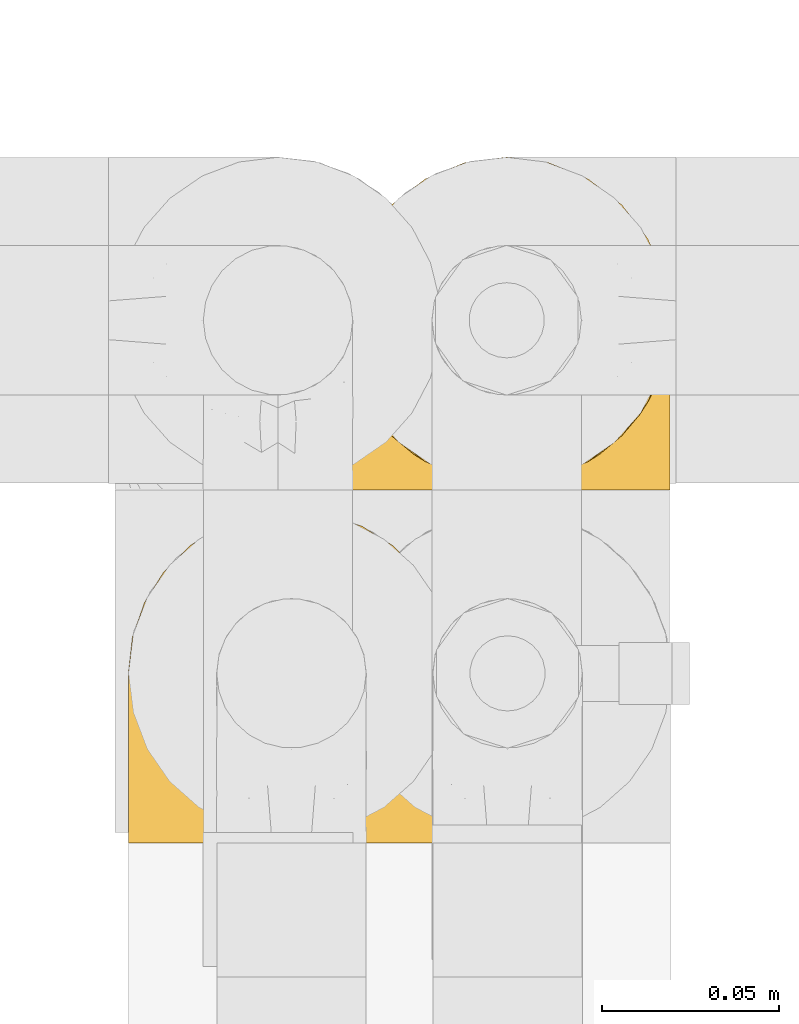
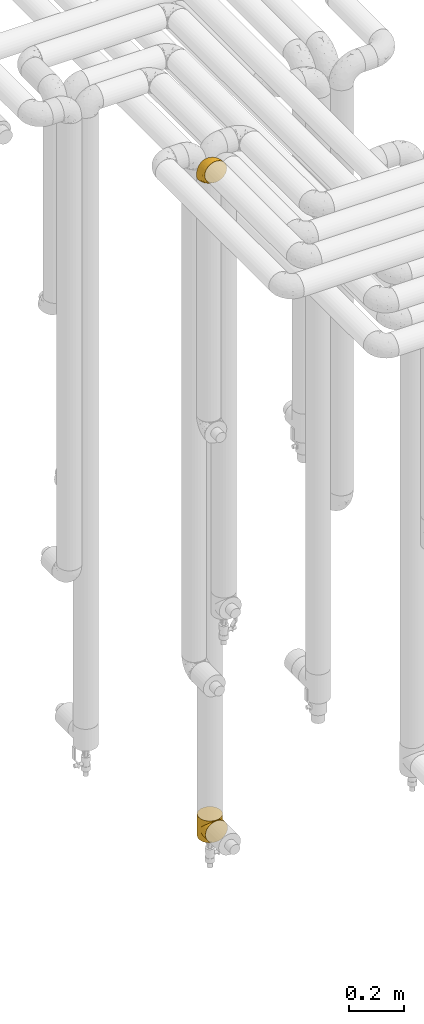
# One storey, part 238 of 827: 2 coverings.
"""IFC2X3 building model written with IfcOpenShell, lengths in millimetres."""

from ifc_helpers import new_model, entity, si_unit, converted_unit, derived_unit, direction, frame, origin, place, context, subcontext, project, spatial, faceted_brep, element, save


model = new_model("IFC2X3")

# Units and contexts
model_context = context("Model", 3, precision=0.01, world=origin(), true_north=direction((6.12303176911189e-17, 1.0)))
body_context = subcontext(model_context, "Body", "Model", "MODEL_VIEW")
ifc_project = project(units=[si_unit("LENGTHUNIT", "METRE", prefix="MILLI"), si_unit("AREAUNIT", "SQUARE_METRE"), si_unit("VOLUMEUNIT", "CUBIC_METRE"), converted_unit("PLANEANGLEUNIT", "DEGREE", entity("IfcRatioMeasure", 0.0174532925199433), si_unit("PLANEANGLEUNIT", "RADIAN"), dimensions=[0, 0, 0, 0, 0, 0, 0]), si_unit("MASSUNIT", "GRAM", prefix="KILO"), derived_unit("MASSDENSITYUNIT", [(si_unit("MASSUNIT", "GRAM", prefix="KILO"), 1), (si_unit("LENGTHUNIT", "METRE"), -3)]), derived_unit("MOMENTOFINERTIAUNIT", [(si_unit("LENGTHUNIT", "METRE"), 4)]), si_unit("TIMEUNIT", "SECOND"), si_unit("FREQUENCYUNIT", "HERTZ"), si_unit("THERMODYNAMICTEMPERATUREUNIT", "DEGREE_CELSIUS"), derived_unit("THERMALTRANSMITTANCEUNIT", [(si_unit("MASSUNIT", "GRAM", prefix="KILO"), 1), (si_unit("THERMODYNAMICTEMPERATUREUNIT", "KELVIN"), -1), (si_unit("TIMEUNIT", "SECOND"), -3)]), derived_unit("VOLUMETRICFLOWRATEUNIT", [(si_unit("LENGTHUNIT", "METRE"), 3), (si_unit("TIMEUNIT", "SECOND"), -1)]), derived_unit("MASSFLOWRATEUNIT", [(si_unit("MASSUNIT", "GRAM", prefix="KILO"), 1), (si_unit("TIMEUNIT", "SECOND"), -1)]), derived_unit("ROTATIONALFREQUENCYUNIT", [(si_unit("TIMEUNIT", "SECOND"), -1)]), si_unit("ELECTRICCURRENTUNIT", "AMPERE"), si_unit("ELECTRICVOLTAGEUNIT", "VOLT"), si_unit("POWERUNIT", "WATT"), si_unit("FORCEUNIT", "NEWTON", prefix="KILO"), si_unit("ILLUMINANCEUNIT", "LUX"), si_unit("LUMINOUSFLUXUNIT", "LUMEN"), si_unit("LUMINOUSINTENSITYUNIT", "CANDELA"), derived_unit("USERDEFINED", [(si_unit("MASSUNIT", "GRAM", prefix="KILO"), -1), (si_unit("LENGTHUNIT", "METRE"), -2), (si_unit("TIMEUNIT", "SECOND"), 3), (si_unit("LUMINOUSFLUXUNIT", "LUMEN"), 1)]), derived_unit("LINEARVELOCITYUNIT", [(si_unit("LENGTHUNIT", "METRE"), 1), (si_unit("TIMEUNIT", "SECOND"), -1)]), si_unit("PRESSUREUNIT", "PASCAL"), derived_unit("USERDEFINED", [(si_unit("LENGTHUNIT", "METRE"), -2), (si_unit("MASSUNIT", "GRAM", prefix="KILO"), 1), (si_unit("TIMEUNIT", "SECOND"), -2)]), derived_unit("LINEARFORCEUNIT", [(si_unit("MASSUNIT", "GRAM", prefix="KILO"), 1), (si_unit("LENGTHUNIT", "METRE"), 1), (si_unit("TIMEUNIT", "SECOND"), -2), (si_unit("LENGTHUNIT", "METRE"), -1)]), derived_unit("PLANARFORCEUNIT", [(si_unit("MASSUNIT", "GRAM", prefix="KILO"), 1), (si_unit("LENGTHUNIT", "METRE"), 1), (si_unit("TIMEUNIT", "SECOND"), -2), (si_unit("LENGTHUNIT", "METRE"), -2)])], contexts=[model_context])

# Site, building, storey
site_placement = place(None, origin())
site = spatial("IfcSite", under=ifc_project, at=site_placement, CompositionType="ELEMENT")
building_placement = place(site_placement, origin())
building = spatial("IfcBuilding", under=site, at=building_placement, CompositionType="ELEMENT")
storey_placement = place(building_placement, frame((0.0, 0.0, 28200.0)))
storey = spatial("IfcBuildingStorey", under=building, at=storey_placement, Name="08", CompositionType="ELEMENT", Elevation=28200.0)

# Coverings
covering_1_placement = place(storey_placement, frame((30683.5, 14968.2, 359.5)))
element("IfcCovering", 1, at=covering_1_placement, inside=storey, Name=":ADSK_", ObjectType=":ADSK_", PredefinedType="INSULATION", context=body_context, shape_type="Brep", body=[
    faceted_brep([(93.48, 41.09, 54.91), (94.0, 48.0, 96.0), (92.42, 36.04, 96.0), (70.23, 7.85, 88.15), (68.11, 6.84, 96.0), (66.38, 5.7, 90.3), (87.81, 24.9, 96.0), (89.25, 27.6, 68.4), (85.44, 21.22, 74.78), (80.46, 15.33, 96.0), (70.9, 7.99, 96.0), (59.75, 3.37, 96.0), (58.58, 3.18, 92.82), (59.69, 3.54, 92.46), (61.92, 4.26, 91.74), (94.0, 48.0, 48.0), (93.48, 41.09, 41.09), (94.0, 48.0, 0.0), (57.46, 2.82, 93.18), (58.26, 3.18, 96.0), (56.76, 2.98, 96.0), (91.91, 34.26, 61.74), (51.53, 2.29, 96.0), (50.78, 2.19, 96.0), (51.42, 2.18, 93.82), (52.28, 2.39, 96.0), (74.07, 10.0, 86.0), (75.68, 11.66, 96.0), (62.54, 4.53, 96.0), (64.15, 4.98, 91.02), (65.32, 5.68, 96.0), (49.29, 2.0, 96.0), (49.0, 1.93, 94.07), (50.21, 2.06, 93.94), (52.63, 2.31, 93.69), (55.27, 2.78, 96.0), (53.77, 2.59, 96.0), (55.05, 2.57, 93.43), (80.41, 15.28, 80.72), (56.26, 2.7, 93.3), (53.84, 2.44, 93.56), (47.8, 1.8, 96.0), (47.8, 1.8, 94.2), (47.8, 1.8, 0.0), (49.0, 1.93, 1.93), (47.8, 1.8, 1.8), (50.04, 2.1, 96.0), (33.66, 4.27, 91.73), (35.84, 3.37, 96.0), (33.05, 4.53, 96.0), (43.31, 2.39, 96.0), (41.82, 2.59, 96.0), (42.95, 2.31, 93.69), (35.89, 3.55, 92.45), (37.0, 3.19, 92.81), (30.27, 5.68, 96.0), (29.21, 5.7, 90.3), (31.43, 4.98, 91.02), (38.11, 2.83, 93.17), (38.83, 2.98, 96.0), (37.33, 3.18, 96.0), (27.48, 6.84, 96.0), (24.7, 7.99, 96.0), (25.37, 7.85, 88.15), (21.52, 10.0, 86.0), (19.91, 11.66, 96.0), (15.18, 15.27, 80.73), (45.37, 2.06, 93.94), (46.3, 2.0, 96.0), (45.55, 2.1, 96.0), (44.81, 2.19, 96.0), (15.13, 15.33, 96.0), (10.15, 21.21, 74.79), (7.78, 24.9, 96.0), (40.53, 2.57, 93.43), (41.74, 2.44, 93.56), (6.34, 27.6, 68.4), (3.17, 36.04, 96.0), (39.32, 2.7, 93.3), (40.32, 2.78, 96.0), (2.11, 41.09, 54.91), (1.6, 48.0, 96.0), (3.69, 34.26, 61.74), (1.6, 48.0, 48.0), (2.11, 41.09, 41.09), (1.6, 48.0, 0.0), (46.59, 1.93, 94.07), (44.16, 2.18, 93.82), (44.06, 2.29, 96.0), (46.59, 1.93, 1.93), (24.7, 88.01, 0.0), (35.84, 92.63, 0.0), (47.8, 94.2, 0.0), (59.75, 92.63, 0.0), (70.9, 88.01, 0.0), (80.46, 80.67, 0.0), (87.81, 71.1, 0.0), (92.42, 59.96, 0.0), (92.42, 36.04, 0.0), (87.81, 24.9, 0.0), (80.46, 15.33, 0.0), (75.68, 11.66, 0.0), (70.9, 7.99, 0.0), (68.11, 6.84, 0.0), (65.32, 5.68, 0.0), (62.54, 4.53, 0.0), (59.75, 3.37, 0.0), (58.26, 3.18, 0.0), (56.76, 2.98, 0.0), (55.27, 2.78, 0.0), (53.77, 2.59, 0.0), (52.28, 2.39, 0.0), (51.53, 2.29, 0.0), (50.78, 2.19, 0.0), (50.04, 2.1, 0.0), (49.29, 2.0, 0.0), (46.3, 2.0, 0.0), (45.55, 2.1, 0.0), (44.81, 2.19, 0.0), (44.06, 2.29, 0.0), (43.31, 2.39, 0.0), (41.82, 2.59, 0.0), (40.32, 2.78, 0.0), (38.83, 2.98, 0.0), (37.33, 3.18, 0.0), (35.84, 3.37, 0.0), (33.05, 4.53, 0.0), (30.27, 5.68, 0.0), (27.48, 6.84, 0.0), (24.7, 7.99, 0.0), (19.91, 11.66, 0.0), (15.13, 15.33, 0.0), (7.78, 24.9, 0.0), (3.17, 36.04, 0.0), (3.17, 59.96, 0.0), (7.78, 71.1, 0.0), (15.13, 80.67, 0.0), (92.42, 59.96, 96.0), (87.81, 71.1, 96.0), (80.46, 80.67, 96.0), (70.9, 88.01, 96.0), (59.75, 92.63, 96.0), (47.8, 94.2, 96.0), (35.84, 92.63, 96.0), (24.7, 88.01, 96.0), (15.13, 80.67, 96.0), (7.78, 71.1, 96.0), (3.17, 59.96, 96.0), (61.92, 4.26, 4.26), (59.69, 3.54, 3.54), (58.58, 3.18, 3.18), (91.91, 34.26, 34.26), (89.25, 27.6, 27.6), (66.38, 5.7, 5.7), (56.26, 2.7, 2.7), (55.05, 2.57, 2.57), (85.44, 21.22, 21.22), (74.07, 10.0, 10.0), (70.23, 7.85, 7.85), (80.41, 15.28, 15.28), (64.15, 4.98, 4.98), (57.46, 2.82, 2.82), (50.21, 2.06, 2.06), (53.84, 2.44, 2.44), (52.63, 2.31, 2.31), (51.42, 2.18, 2.18), (29.21, 5.7, 5.7), (31.43, 4.98, 4.98), (21.52, 10.0, 10.0), (40.53, 2.57, 2.57), (15.18, 15.27, 15.27), (25.37, 7.85, 7.85), (39.32, 2.7, 2.7), (38.11, 2.83, 2.83), (44.16, 2.18, 2.18), (42.95, 2.31, 2.31), (33.66, 4.27, 4.27), (37.0, 3.19, 3.19), (35.89, 3.55, 3.55), (6.34, 27.6, 27.6), (3.69, 34.26, 34.26), (10.15, 21.21, 21.21), (41.74, 2.44, 2.44), (45.37, 2.06, 2.06), (94.0, 0.0, 48.0), (92.42, 0.0, 59.96), (87.81, 0.0, 71.1), (80.46, 0.0, 80.67), (75.68, 0.0, 84.34), (70.9, 0.0, 88.01), (68.11, 0.0, 89.16), (65.32, 0.0, 90.32), (62.54, 0.0, 91.47), (59.75, 0.0, 92.63), (58.26, 0.0, 92.82), (56.76, 0.0, 93.02), (55.27, 0.0, 93.22), (53.77, 0.0, 93.41), (52.28, 0.0, 93.61), (51.53, 0.0, 93.71), (50.78, 0.0, 93.81), (50.04, 0.0, 93.9), (49.29, 0.0, 94.0), (47.8, 0.0, 94.2), (46.3, 0.0, 94.0), (45.55, 0.0, 93.9), (44.81, 0.0, 93.81), (44.06, 0.0, 93.71), (43.31, 0.0, 93.61), (41.82, 0.0, 93.41), (40.32, 0.0, 93.22), (38.83, 0.0, 93.02), (37.33, 0.0, 92.82), (35.84, 0.0, 92.63), (33.05, 0.0, 91.47), (30.27, 0.0, 90.32), (27.48, 0.0, 89.16), (24.7, 0.0, 88.01), (19.91, 0.0, 84.34), (15.13, 0.0, 80.67), (7.78, 0.0, 71.1), (3.17, 0.0, 59.96), (1.6, 0.0, 48.0), (3.17, 0.0, 36.04), (7.78, 0.0, 24.9), (15.13, 0.0, 15.33), (19.91, 0.0, 11.66), (24.7, 0.0, 7.99), (27.48, 0.0, 6.84), (30.27, 0.0, 5.68), (33.05, 0.0, 4.53), (35.84, 0.0, 3.37), (37.33, 0.0, 3.18), (38.83, 0.0, 2.98), (40.32, 0.0, 2.78), (41.82, 0.0, 2.59), (43.31, 0.0, 2.39), (44.06, 0.0, 2.29), (44.81, 0.0, 2.19), (45.55, 0.0, 2.1), (46.3, 0.0, 2.0), (47.8, 0.0, 1.8), (49.29, 0.0, 2.0), (50.04, 0.0, 2.1), (50.78, 0.0, 2.19), (51.53, 0.0, 2.29), (52.28, 0.0, 2.39), (53.77, 0.0, 2.59), (55.27, 0.0, 2.78), (56.76, 0.0, 2.98), (58.26, 0.0, 3.18), (59.75, 0.0, 3.37), (62.54, 0.0, 4.53), (65.32, 0.0, 5.68), (68.11, 0.0, 6.84), (70.9, 0.0, 7.99), (75.68, 0.0, 11.66), (80.46, 0.0, 15.33), (87.81, 0.0, 24.9), (92.42, 0.0, 36.04)], [[[0, 1, 2]], [[3, 4, 5]], [[2, 6, 7]], [[8, 6, 9]], [[4, 3, 10]], [[8, 7, 6]], [[11, 12, 13, 14]], [[0, 15, 1]], [[15, 16, 17]], [[18, 19, 20]], [[7, 21, 2]], [[0, 2, 21]], [[19, 18, 12]], [[12, 11, 19]], [[22, 23, 24, 25]], [[26, 27, 10]], [[28, 29, 30]], [[28, 11, 14]], [[31, 32, 33]], [[29, 28, 14]], [[34, 25, 24]], [[35, 36, 37]], [[38, 9, 27]], [[38, 27, 26]], [[5, 30, 29]], [[20, 39, 18]], [[5, 4, 30]], [[26, 10, 3]], [[35, 39, 20]], [[9, 38, 8]], [[36, 34, 40, 37]], [[34, 36, 25]], [[39, 35, 37]], [[32, 41, 42]], [[43, 44, 45]], [[23, 33, 24]], [[33, 23, 46, 31]], [[41, 32, 31]], [[47, 48, 49]], [[50, 51, 52]], [[48, 47, 53, 54]], [[55, 56, 57]], [[58, 59, 60]], [[61, 62, 63]], [[49, 57, 47]], [[58, 60, 54]], [[64, 62, 65]], [[66, 64, 65]], [[61, 63, 56]], [[67, 68, 69, 70]], [[65, 71, 66]], [[62, 64, 63]], [[72, 71, 73]], [[51, 74, 75, 52]], [[76, 73, 77]], [[78, 79, 59]], [[59, 58, 78]], [[80, 77, 81]], [[79, 78, 74]], [[76, 72, 73]], [[80, 82, 77]], [[83, 80, 81]], [[84, 83, 85]], [[56, 55, 61]], [[76, 77, 82]], [[57, 49, 55]], [[48, 54, 60]], [[71, 72, 66]], [[74, 51, 79]], [[86, 41, 68]], [[87, 50, 52]], [[70, 87, 67]], [[50, 87, 70, 88]], [[41, 86, 42]], [[89, 43, 45]], [[68, 67, 86]], [[90, 91, 92, 93, 94, 95, 96, 97, 17, 98, 99, 100, 101, 102, 103, 104, 105, 106, 107, 108, 109, 110, 111, 112, 113, 114, 115, 43, 116, 117, 118, 119, 120, 121, 122, 123, 124, 125, 126, 127, 128, 129, 130, 131, 132, 133, 85, 134, 135, 136]], [[1, 137, 138, 139, 140, 141, 142, 143, 144, 145, 146, 147, 81, 77, 73, 71, 65, 62, 61, 55, 49, 48, 60, 59, 79, 51, 50, 88, 70, 69, 68, 41, 31, 46, 23, 22, 25, 36, 35, 20, 19, 11, 28, 30, 4, 10, 27, 9, 6, 2]], [[140, 139, 95, 94]], [[92, 142, 141, 93]], [[141, 140, 94, 93]], [[96, 138, 137, 97]], [[1, 15, 17, 97, 137]], [[95, 139, 138, 96]], [[106, 148, 149, 150]], [[151, 152, 98]], [[153, 104, 103]], [[148, 106, 105]], [[16, 151, 98]], [[109, 154, 155]], [[17, 16, 98]], [[99, 156, 100]], [[99, 98, 152]], [[156, 99, 152]], [[102, 157, 158]], [[106, 150, 107]], [[155, 110, 109]], [[157, 101, 159]], [[105, 160, 148]], [[161, 107, 150]], [[162, 115, 114, 113]], [[157, 102, 101]], [[153, 103, 158]], [[104, 153, 160]], [[159, 101, 100]], [[102, 158, 103]], [[108, 161, 154]], [[110, 155, 163, 164]], [[164, 111, 110]], [[161, 108, 107]], [[160, 105, 104]], [[159, 100, 156]], [[154, 109, 108]], [[44, 43, 115]], [[165, 111, 164]], [[113, 165, 162]], [[111, 165, 113, 112]], [[115, 162, 44]], [[166, 127, 167]], [[166, 128, 127]], [[129, 168, 130]], [[122, 121, 169]], [[170, 130, 168]], [[171, 168, 129]], [[123, 172, 173]], [[119, 118, 174, 120]], [[128, 171, 129]], [[174, 175, 120]], [[126, 125, 176]], [[171, 128, 166]], [[170, 131, 130]], [[125, 177, 178, 176]], [[179, 180, 133]], [[173, 124, 123]], [[177, 125, 124]], [[180, 84, 133]], [[131, 181, 132]], [[181, 131, 170]], [[179, 132, 181]], [[179, 133, 132]], [[121, 175, 182, 169]], [[167, 126, 176]], [[84, 85, 133]], [[126, 167, 127]], [[122, 172, 123]], [[124, 173, 177]], [[116, 89, 183]], [[175, 121, 120]], [[172, 122, 169]], [[118, 183, 174]], [[183, 118, 117, 116]], [[43, 89, 116]], [[83, 81, 147, 134, 85]], [[134, 147, 146, 135]], [[146, 145, 136, 135]], [[136, 145, 144, 90]], [[90, 144, 143, 91]], [[91, 143, 142, 92]], [[184, 185, 186, 187, 188, 189, 190, 191, 192, 193, 194, 195, 196, 197, 198, 199, 200, 201, 202, 203, 204, 205, 206, 207, 208, 209, 210, 211, 212, 213, 214, 215, 216, 217, 218, 219, 220, 221, 222, 223, 224, 225, 226, 227, 228, 229, 230, 231, 232, 233, 234, 235, 236, 237, 238, 239, 240, 241, 242, 243, 244, 245, 246, 247, 248, 249, 250, 251, 252, 253, 254, 255, 256, 257, 258, 259]], [[39, 196, 195]], [[198, 197, 34]], [[193, 14, 13, 12]], [[5, 191, 190]], [[14, 193, 192]], [[190, 189, 3]], [[192, 29, 14]], [[18, 194, 12]], [[26, 189, 188]], [[38, 26, 188]], [[190, 3, 5]], [[33, 202, 201, 200]], [[188, 187, 38]], [[189, 26, 3]], [[8, 187, 186]], [[29, 192, 191]], [[7, 186, 185]], [[193, 12, 194]], [[0, 185, 184]], [[191, 5, 29]], [[7, 8, 186]], [[197, 37, 40, 34]], [[0, 21, 185]], [[15, 0, 184]], [[18, 195, 194]], [[7, 185, 21]], [[196, 39, 37]], [[187, 8, 38]], [[37, 197, 196]], [[195, 18, 39]], [[32, 203, 202]], [[24, 198, 34]], [[200, 24, 33]], [[198, 24, 200, 199]], [[203, 32, 42]], [[202, 33, 32]], [[16, 184, 259]], [[158, 254, 153]], [[259, 258, 152]], [[156, 258, 257]], [[254, 158, 255]], [[156, 152, 258]], [[251, 150, 149, 148]], [[16, 15, 184]], [[161, 250, 249]], [[152, 151, 259]], [[16, 259, 151]], [[250, 161, 150]], [[150, 251, 250]], [[245, 244, 165, 246]], [[157, 256, 255]], [[252, 160, 253]], [[252, 251, 148]], [[242, 44, 162]], [[160, 252, 148]], [[164, 246, 165]], [[248, 247, 155]], [[159, 257, 256]], [[159, 256, 157]], [[153, 253, 160]], [[249, 154, 161]], [[153, 254, 253]], [[157, 255, 158]], [[248, 154, 249]], [[257, 159, 156]], [[247, 164, 163, 155]], [[164, 247, 246]], [[154, 248, 155]], [[44, 241, 45]], [[244, 162, 165]], [[162, 244, 243, 242]], [[241, 44, 242]], [[176, 231, 230]], [[236, 235, 175]], [[231, 176, 178, 177]], [[229, 166, 167]], [[173, 233, 232]], [[228, 227, 171]], [[230, 167, 176]], [[173, 232, 177]], [[168, 227, 226]], [[170, 168, 226]], [[228, 171, 166]], [[183, 240, 239, 238]], [[226, 225, 170]], [[227, 168, 171]], [[181, 225, 224]], [[235, 169, 182, 175]], [[179, 224, 223]], [[172, 234, 233]], [[233, 173, 172]], [[84, 223, 222]], [[234, 172, 169]], [[179, 181, 224]], [[84, 180, 223]], [[83, 84, 222]], [[166, 229, 228]], [[179, 223, 180]], [[167, 230, 229]], [[231, 177, 232]], [[225, 181, 170]], [[169, 235, 234]], [[89, 241, 240]], [[174, 236, 175]], [[238, 174, 183]], [[236, 174, 238, 237]], [[241, 89, 45]], [[240, 183, 89]], [[80, 222, 221]], [[209, 52, 75, 74]], [[221, 220, 76]], [[72, 220, 219]], [[210, 78, 211]], [[72, 76, 220]], [[63, 216, 56]], [[80, 83, 222]], [[54, 213, 212]], [[76, 82, 221]], [[80, 221, 82]], [[58, 212, 211]], [[216, 63, 217]], [[207, 206, 87, 208]], [[64, 218, 217]], [[204, 86, 67]], [[214, 213, 47]], [[57, 214, 47]], [[212, 58, 54]], [[52, 208, 87]], [[210, 209, 74]], [[66, 219, 218]], [[66, 218, 64]], [[56, 215, 57]], [[211, 78, 58]], [[56, 216, 215]], [[64, 217, 63]], [[213, 54, 53, 47]], [[219, 66, 72]], [[214, 57, 215]], [[52, 209, 208]], [[78, 210, 74]], [[86, 203, 42]], [[206, 67, 87]], [[67, 206, 205, 204]], [[203, 86, 204]]]),
])
covering_2_placement = place(storey_placement, frame((30622.54, 14866.61, 3350.4)))
element("IfcCovering", 2, at=covering_2_placement, inside=storey, Name=":ADSK_", ObjectType=":ADSK_", PredefinedType="INSULATION", context=body_context, shape_type="Brep", body=[
    faceted_brep([(11.68, 78.41, 1.6), (19.0, 85.72, 1.6), (27.76, 91.22, 1.6), (37.52, 94.64, 1.6), (47.8, 95.8, 1.6), (58.08, 94.64, 1.6), (67.85, 91.22, 1.6), (76.61, 85.71, 1.6), (83.92, 78.39, 1.6), (89.42, 69.63, 1.6), (92.84, 59.87, 1.6), (94.0, 49.6, 1.6), (93.53, 45.45, 1.6), (93.18, 42.38, 1.6), (92.84, 39.31, 1.6), (91.13, 34.43, 1.6), (89.42, 29.54, 1.6), (86.66, 25.16, 1.6), (83.91, 20.78, 1.6), (80.25, 17.13, 1.6), (76.59, 13.47, 1.6), (67.83, 7.97, 1.6), (62.95, 6.26, 1.6), (58.07, 4.55, 1.6), (47.8, 3.4, 1.6), (37.51, 4.55, 1.6), (32.63, 6.26, 1.6), (27.74, 7.97, 1.6), (18.98, 13.48, 1.6), (15.33, 17.14, 1.6), (11.67, 20.8, 1.6), (8.92, 25.18, 1.6), (6.17, 29.56, 1.6), (4.46, 34.44, 1.6), (2.75, 39.32, 1.6), (2.41, 42.39, 1.6), (2.06, 45.45, 1.6), (1.6, 49.6, 1.6), (2.75, 59.88, 1.6), (6.17, 69.65, 1.6), (47.8, 1.6, 3.4), (59.75, 1.6, 4.97), (70.9, 1.6, 9.58), (75.68, 1.6, 13.26), (80.46, 1.6, 16.93), (84.13, 1.6, 21.71), (87.81, 1.6, 26.5), (90.11, 1.6, 32.07), (92.42, 1.6, 37.64), (92.9, 1.6, 41.25), (93.17, 1.6, 43.34), (93.45, 1.6, 45.42), (94.0, 1.6, 49.6), (92.42, 1.6, 61.55), (87.81, 1.6, 72.7), (80.46, 1.6, 82.26), (70.9, 1.6, 89.61), (59.75, 1.6, 94.22), (47.8, 1.6, 95.8), (35.84, 1.6, 94.22), (24.7, 1.6, 89.61), (15.13, 1.6, 82.26), (7.78, 1.6, 72.7), (3.17, 1.6, 61.55), (1.6, 1.6, 49.6), (2.14, 1.6, 45.42), (2.69, 1.6, 41.25), (3.17, 1.6, 37.64), (5.48, 1.6, 32.07), (7.78, 1.6, 26.5), (11.46, 1.6, 21.71), (15.13, 1.6, 16.93), (19.91, 1.6, 13.26), (24.7, 1.6, 9.58), (35.84, 1.6, 4.97), (23.61, 36.81, 81.55), (31.99, 23.28, 90.4), (35.87, 45.8, 83.0), (47.8, 30.7, 91.18), (40.43, 21.2, 93.13), (47.8, 12.96, 94.0), (31.83, 66.19, 66.19), (23.37, 54.51, 70.92), (21.41, 17.98, 85.95), (3.07, 36.69, 49.74), (1.6, 35.54, 35.54), (1.6, 31.64, 38.14), (1.6, 27.75, 40.74), (1.6, 23.86, 43.34), (1.6, 19.96, 45.94), (13.45, 22.8, 77.59), (15.25, 42.67, 71.17), (8.07, 33.21, 65.81), (16.0, 59.45, 59.03), (17.34, 71.5, 45.85), (10.58, 62.66, 45.79), (5.34, 54.5, 41.42), (2.39, 47.57, 34.51), (8.36, 48.81, 56.04), (10.04, 74.98, 15.15), (2.59, 18.7, 56.51), (6.28, 15.75, 68.39), (34.28, 91.17, 23.33), (38.73, 85.28, 42.86), (27.25, 82.58, 39.42), (29.88, 75.78, 53.58), (38.6, 74.98, 59.17), (23.44, 67.27, 59.06), (25.25, 87.38, 22.63), (17.23, 82.04, 20.55), (47.8, 94.0, 12.96), (47.8, 77.8, 56.96), (47.8, 67.38, 67.38), (2.53, 56.2, 18.72), (1.6, 48.85, 5.33), (1.6, 48.11, 9.07), (1.6, 47.57, 11.79), (1.6, 47.03, 14.51), (1.6, 46.48, 17.24), (1.6, 45.94, 19.96), (5.71, 65.78, 21.03), (1.6, 17.24, 46.48), (1.6, 14.51, 47.03), (1.6, 11.79, 47.57), (1.6, 9.07, 48.11), (1.6, 7.2, 48.48), (1.6, 5.33, 48.85), (47.8, 91.18, 30.7), (1.6, 43.34, 23.86), (1.6, 40.74, 27.75), (1.6, 38.14, 31.64), (11.89, 72.73, 31.26), (47.8, 56.96, 77.8), (39.69, 62.23, 72.75), (47.8, 84.49, 43.83), (47.8, 43.83, 84.49), (13.84, 12.05, 14.58), (9.16, 18.95, 16.17), (15.79, 13.02, 10.82), (25.75, 8.34, 4.64), (16.09, 14.63, 7.71), (7.51, 11.09, 25.13), (3.99, 13.66, 32.66), (2.66, 20.08, 34.94), (3.16, 9.61, 36.76), (2.35, 9.48, 40.48), (2.23, 16.1, 39.25), (38.35, 3.42, 3.69), (6.18, 26.63, 13.99), (2.7, 33.72, 21.85), (2.93, 34.77, 17.93), (16.01, 6.75, 15.11), (9.08, 13.31, 21.14), (9.3, 21.11, 12.7), (11.68, 19.94, 7.21), (4.65, 8.67, 32.27), (3.65, 26.11, 25.68), (3.61, 29.3, 22.18), (12.8, 6.32, 18.79), (2.43, 39.92, 10.12), (6.83, 27.05, 9.47), (21.65, 6.04, 10.45), (3.7, 34.4, 11.29), (47.8, 2.87, 2.87), (3.37, 20.92, 31.16), (7.03, 27.43, 6.31), (7.87, 7.54, 25.62), (7.26, 18.45, 21.18), (3.41, 23.88, 28.81), (23.81, 7.77, 7.45), (86.5, 13.3, 21.14), (88.08, 11.09, 25.13), (82.79, 6.33, 18.79), (94.0, 9.07, 48.11), (94.0, 5.33, 48.85), (94.0, 14.51, 47.03), (94.0, 11.79, 47.57), (57.24, 3.42, 3.69), (71.76, 7.76, 7.44), (94.0, 47.03, 14.51), (94.0, 47.57, 11.79), (94.0, 48.85, 5.33), (94.0, 48.11, 9.07), (79.49, 14.62, 7.71), (88.75, 27.03, 9.47), (92.93, 20.08, 34.94), (92.22, 20.92, 31.16), (94.0, 27.75, 40.74), (94.0, 31.64, 38.14), (92.43, 9.61, 36.76), (93.24, 9.48, 40.48), (69.82, 8.33, 4.63), (79.57, 6.74, 15.11), (81.74, 12.04, 14.58), (94.0, 23.86, 43.34), (94.0, 19.96, 45.94), (93.36, 16.1, 39.25), (83.9, 19.93, 7.21), (86.28, 21.1, 12.69), (93.16, 39.92, 10.14), (92.88, 33.68, 21.81), (91.98, 29.28, 22.19), (89.41, 26.62, 14.0), (91.93, 26.08, 25.69), (86.42, 18.93, 16.17), (88.82, 27.87, 6.66), (92.66, 34.75, 17.92), (73.93, 6.04, 10.45), (94.0, 38.14, 31.64), (79.5, 12.79, 10.64), (91.89, 34.41, 11.31), (94.0, 45.94, 19.96), (94.0, 43.34, 23.86), (94.0, 40.74, 27.75), (91.6, 13.66, 32.66), (94.0, 17.24, 46.48), (90.94, 8.67, 32.27), (94.0, 35.54, 35.54), (92.16, 23.83, 28.77), (88.32, 18.43, 21.17), (86.13, 6.03, 23.36), (94.0, 46.48, 17.24), (93.2, 34.52, 47.58), (55.16, 21.2, 93.13), (82.02, 23.82, 77.44), (84.29, 41.32, 66.78), (76.94, 47.62, 71.68), (68.33, 52.66, 74.96), (71.98, 36.81, 81.55), (92.52, 49.75, 36.7), (92.9, 19.07, 56.9), (59.72, 45.8, 83.0), (63.6, 23.28, 90.4), (88.89, 21.35, 67.83), (74.18, 17.98, 85.95), (68.35, 82.57, 39.41), (61.33, 91.17, 23.33), (56.86, 85.27, 42.87), (68.62, 73.89, 53.92), (63.76, 66.19, 66.19), (72.19, 62.43, 64.12), (88.69, 63.53, 33.13), (92.19, 58.45, 23.1), (89.75, 67.16, 16.98), (59.86, 76.72, 55.72), (55.9, 62.22, 72.75), (77.99, 81.54, 23.77), (85.21, 74.8, 18.41), (74.99, 75.83, 43.7), (90.23, 41.45, 54.53), (70.75, 88.2, 17.73), (81.72, 71.6, 38.98), (86.53, 56.23, 50.28), (79.6, 59.44, 59.02)], [[[0, 1, 2, 3, 4, 5, 6, 7, 8, 9, 10, 11, 12, 13, 14, 15, 16, 17, 18, 19, 20, 21, 22, 23, 24, 25, 26, 27, 28, 29, 30, 31, 32, 33, 34, 35, 36, 37, 38, 39]], [[40, 41, 42, 43, 44, 45, 46, 47, 48, 49, 50, 51, 52, 53, 54, 55, 56, 57, 58, 59, 60, 61, 62, 63, 64, 65, 66, 67, 68, 69, 70, 71, 72, 73, 74]], [[75, 76, 77]], [[78, 79, 80]], [[77, 81, 82]], [[76, 75, 83]], [[84, 85, 86, 87, 88, 89]], [[90, 91, 92]], [[76, 60, 59]], [[93, 94, 95]], [[90, 62, 61]], [[83, 61, 60]], [[96, 97, 84]], [[98, 93, 95]], [[0, 39, 99]], [[100, 84, 89]], [[62, 101, 63]], [[2, 102, 3]], [[92, 84, 100]], [[103, 102, 104]], [[103, 105, 106]], [[93, 107, 94]], [[1, 108, 2]], [[92, 101, 90]], [[108, 1, 109]], [[102, 110, 3]], [[93, 82, 107]], [[102, 108, 104]], [[111, 106, 112]], [[109, 0, 99]], [[113, 37, 114, 115, 116, 117, 118, 119]], [[120, 38, 113]], [[100, 89, 121, 122, 123, 124, 125, 126, 64]], [[127, 102, 103]], [[97, 119, 128, 129, 130, 85]], [[99, 120, 131]], [[132, 133, 77]], [[59, 80, 79]], [[1, 0, 109]], [[98, 84, 92]], [[94, 109, 131]], [[120, 39, 38]], [[93, 91, 82]], [[104, 94, 105]], [[97, 113, 119]], [[95, 120, 96]], [[83, 90, 61]], [[91, 93, 98]], [[64, 63, 100]], [[100, 63, 101]], [[77, 76, 79]], [[133, 106, 81]], [[84, 97, 85]], [[113, 96, 120]], [[113, 97, 96]], [[37, 113, 38]], [[110, 102, 127]], [[110, 4, 3]], [[103, 111, 134, 127]], [[90, 75, 91]], [[82, 81, 107]], [[91, 75, 82]], [[77, 82, 75]], [[76, 83, 60]], [[90, 83, 75]], [[105, 107, 81]], [[94, 131, 95]], [[105, 94, 107]], [[109, 94, 104]], [[120, 95, 131]], [[98, 95, 96]], [[84, 98, 96]], [[98, 92, 91]], [[106, 105, 81]], [[103, 104, 105]], [[112, 106, 133]], [[103, 106, 111]], [[112, 133, 132]], [[81, 77, 133]], [[77, 78, 135, 132]], [[120, 99, 39]], [[109, 99, 131]], [[59, 58, 80]], [[59, 79, 76]], [[90, 101, 62]], [[100, 101, 92]], [[2, 108, 102]], [[109, 104, 108]], [[78, 77, 79]], [[136, 137, 138]], [[27, 139, 140]], [[141, 142, 143]], [[144, 145, 121]], [[146, 89, 88]], [[147, 139, 25]], [[148, 149, 150]], [[136, 151, 152]], [[147, 40, 74]], [[24, 147, 25]], [[140, 153, 154]], [[33, 116, 34]], [[73, 72, 151]], [[114, 37, 36, 35, 34, 116, 115]], [[146, 155, 144]], [[156, 85, 130]], [[157, 149, 148]], [[151, 158, 152]], [[117, 33, 159]], [[29, 154, 160]], [[161, 74, 73]], [[162, 128, 119]], [[66, 65, 64, 126, 125, 124, 123, 122, 67]], [[163, 147, 24]], [[27, 140, 28]], [[149, 129, 150]], [[139, 27, 26, 25]], [[68, 144, 69]], [[129, 128, 150]], [[164, 87, 86]], [[130, 129, 149]], [[122, 145, 67]], [[154, 153, 148]], [[162, 119, 159]], [[165, 30, 160]], [[150, 160, 148]], [[128, 162, 150]], [[30, 165, 31]], [[145, 144, 68]], [[89, 146, 144]], [[87, 164, 143]], [[166, 155, 142]], [[88, 87, 143]], [[162, 160, 150]], [[160, 30, 29]], [[154, 29, 28]], [[140, 154, 28]], [[160, 154, 148]], [[140, 137, 153]], [[157, 148, 153]], [[156, 130, 157]], [[153, 137, 157]], [[157, 137, 156]], [[167, 137, 136]], [[168, 85, 156]], [[152, 168, 167]], [[167, 168, 156]], [[164, 152, 141]], [[71, 158, 72]], [[152, 167, 136]], [[88, 142, 146]], [[144, 155, 69]], [[146, 142, 155]], [[70, 166, 71]], [[142, 141, 166]], [[70, 69, 155]], [[141, 158, 71]], [[161, 73, 151]], [[138, 137, 140]], [[161, 136, 169]], [[136, 161, 151]], [[74, 161, 169]], [[152, 158, 141]], [[151, 72, 158]], [[168, 152, 164]], [[137, 167, 156]], [[164, 86, 168]], [[85, 168, 86]], [[116, 33, 117]], [[130, 149, 157]], [[67, 145, 68]], [[121, 89, 144]], [[145, 122, 121]], [[40, 147, 163]], [[169, 147, 74]], [[159, 33, 32]], [[162, 159, 32]], [[159, 119, 118, 117]], [[139, 147, 169]], [[139, 169, 138]], [[162, 32, 31]], [[141, 143, 164]], [[88, 143, 142]], [[71, 166, 141]], [[155, 166, 70]], [[139, 138, 140]], [[169, 136, 138]], [[160, 162, 165]], [[162, 31, 165]], [[170, 171, 172]], [[173, 174, 52, 51, 50, 49, 48, 175, 176]], [[177, 178, 41]], [[179, 15, 180]], [[12, 11, 181, 182, 180, 14, 13]], [[183, 21, 20]], [[19, 18, 184]], [[185, 186, 187]], [[186, 188, 187]], [[43, 172, 44]], [[189, 190, 47]], [[23, 22, 21, 191]], [[170, 192, 193]], [[40, 163, 177]], [[194, 195, 196]], [[24, 23, 177]], [[197, 198, 183]], [[199, 15, 179]], [[47, 46, 189]], [[200, 201, 202]], [[201, 203, 204]], [[205, 206, 184]], [[207, 41, 178]], [[16, 15, 199]], [[14, 180, 15]], [[202, 201, 198]], [[208, 201, 200]], [[163, 24, 177]], [[48, 47, 190]], [[196, 195, 189]], [[197, 184, 202]], [[204, 193, 209]], [[210, 211, 212]], [[206, 212, 213]], [[205, 17, 210]], [[184, 206, 202]], [[210, 212, 206]], [[185, 194, 214]], [[189, 215, 190]], [[216, 45, 214]], [[186, 171, 170]], [[189, 216, 196]], [[197, 20, 19]], [[194, 185, 187]], [[197, 183, 20]], [[184, 197, 19]], [[197, 202, 198]], [[206, 200, 202]], [[204, 183, 198]], [[201, 208, 203]], [[203, 208, 217]], [[204, 198, 201]], [[217, 188, 218]], [[193, 219, 170]], [[171, 186, 185]], [[170, 218, 186]], [[170, 219, 218]], [[42, 207, 192]], [[171, 220, 172]], [[216, 189, 46]], [[214, 194, 196]], [[44, 220, 45]], [[214, 196, 216]], [[216, 46, 45]], [[214, 45, 220]], [[192, 43, 42]], [[204, 203, 219]], [[207, 193, 192]], [[209, 193, 178]], [[41, 207, 42]], [[193, 207, 178]], [[43, 192, 172]], [[170, 172, 192]], [[204, 219, 193]], [[219, 203, 218]], [[217, 218, 203]], [[188, 186, 218]], [[206, 213, 200]], [[208, 200, 213]], [[199, 210, 16]], [[215, 189, 195]], [[215, 175, 190]], [[175, 48, 190]], [[199, 179, 221, 211]], [[210, 199, 211]], [[23, 191, 177]], [[40, 177, 41]], [[178, 177, 191]], [[21, 183, 191]], [[209, 191, 183]], [[205, 18, 17]], [[17, 16, 210]], [[171, 185, 214]], [[172, 220, 44]], [[214, 220, 171]], [[191, 209, 178]], [[204, 209, 183]], [[206, 205, 210]], [[18, 205, 184]], [[222, 195, 194, 187, 188, 217]], [[57, 223, 80]], [[224, 225, 226]], [[226, 227, 228]], [[229, 217, 208, 213, 212, 211]], [[230, 52, 174, 173, 176, 175, 215, 195]], [[231, 232, 228]], [[231, 78, 223]], [[223, 57, 232]], [[224, 233, 225]], [[233, 54, 53]], [[234, 232, 56]], [[56, 55, 234]], [[234, 224, 228]], [[235, 236, 237]], [[224, 55, 54]], [[238, 239, 240]], [[52, 230, 53]], [[241, 242, 243]], [[239, 244, 245]], [[11, 10, 242]], [[236, 6, 5]], [[7, 246, 8]], [[8, 247, 9]], [[238, 248, 235]], [[222, 229, 249]], [[242, 211, 221, 179, 180, 182, 181, 11]], [[233, 53, 230]], [[111, 112, 244]], [[250, 6, 236]], [[247, 251, 241]], [[6, 250, 7]], [[127, 236, 110]], [[249, 229, 252]], [[247, 8, 246]], [[235, 246, 250]], [[236, 5, 110]], [[235, 244, 238]], [[237, 236, 127]], [[243, 9, 247]], [[252, 229, 241]], [[56, 232, 57]], [[222, 230, 195]], [[225, 249, 252]], [[249, 233, 230]], [[54, 233, 224]], [[231, 228, 227]], [[245, 132, 231]], [[249, 225, 233]], [[226, 225, 253]], [[235, 250, 236]], [[246, 7, 250]], [[251, 247, 246]], [[243, 247, 241]], [[248, 246, 235]], [[252, 251, 253]], [[229, 222, 217]], [[230, 222, 249]], [[5, 4, 110]], [[237, 127, 134, 111]], [[238, 244, 239]], [[224, 234, 55]], [[232, 234, 228]], [[242, 241, 229]], [[10, 9, 243]], [[211, 242, 229]], [[10, 243, 242]], [[80, 223, 78]], [[80, 58, 57]], [[231, 223, 232]], [[227, 240, 239]], [[224, 226, 228]], [[240, 226, 253]], [[227, 239, 245]], [[226, 240, 227]], [[251, 248, 253]], [[240, 253, 248]], [[244, 235, 237]], [[237, 111, 244]], [[132, 245, 112]], [[112, 245, 244]], [[135, 78, 231, 132]], [[227, 245, 231]], [[248, 238, 240]], [[246, 248, 251]], [[251, 252, 241]], [[225, 252, 253]]]),
])

save(model, "model.ifc")
